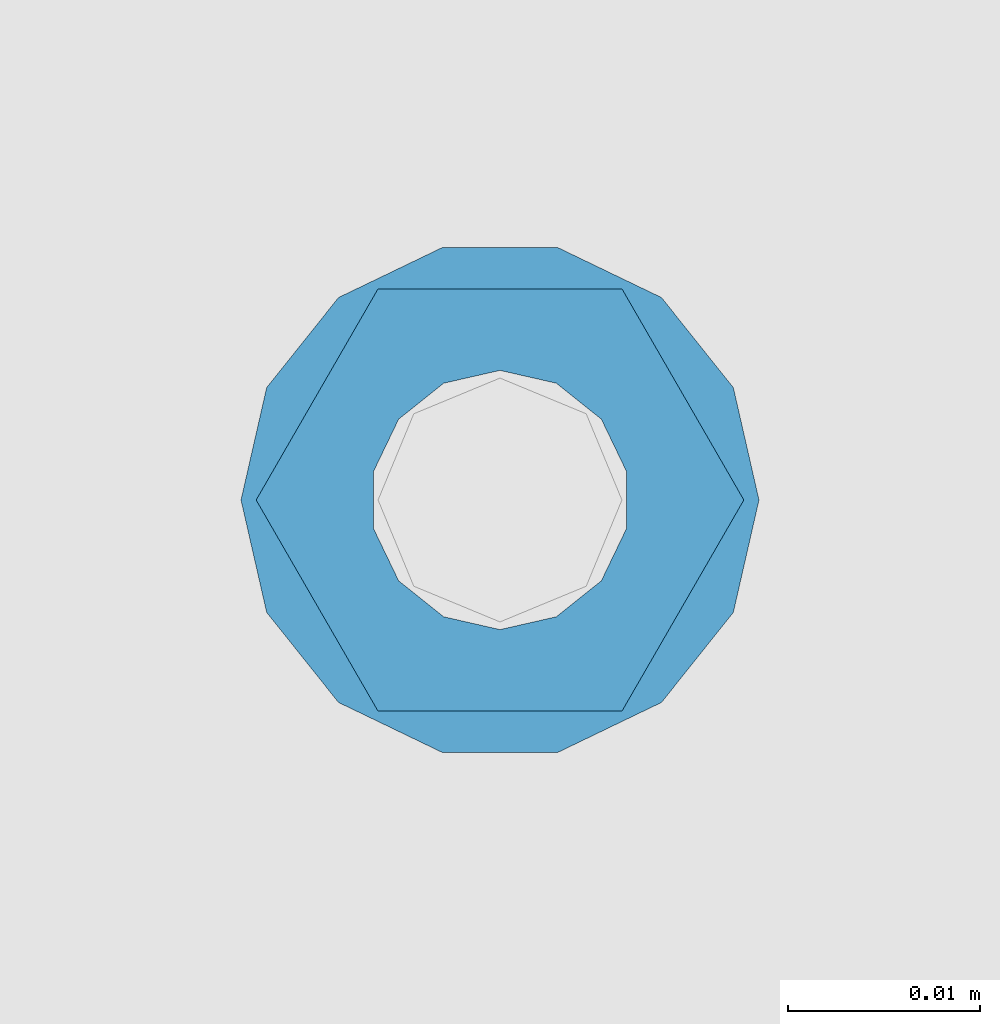
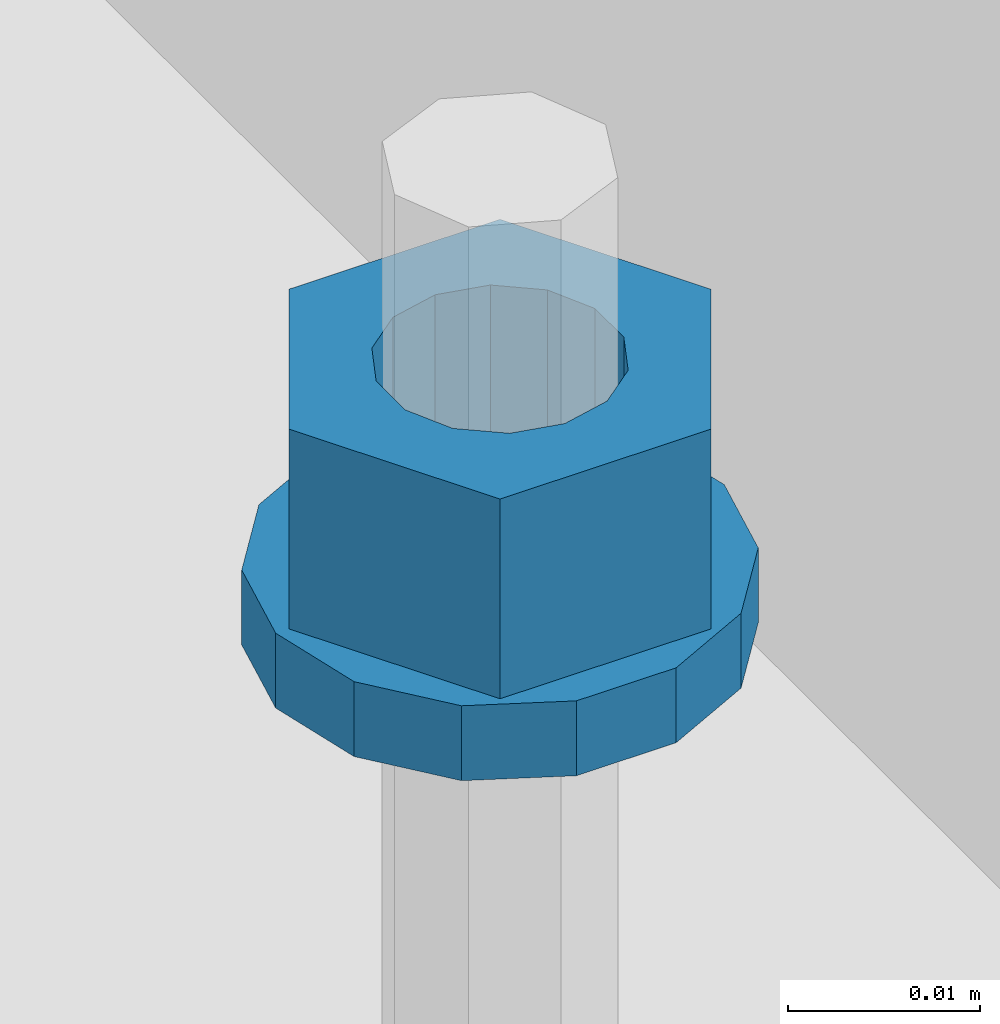
# One storey, part 623 of 1179: 2 columns, 1 element without a shape of its own.
"""IFC2X3 building model written with IfcOpenShell, lengths in millimetres."""

import ifcopenshell
import ifcopenshell.guid

model = None  # the IFC model being written
_history = None  # IfcOwnerHistory: only IFC2X3 demands one
_inside = {}  # id of a spatial element -> (the spatial element, [elements in it])
_under = {}  # id of a project, library or spatial element -> (it, [spatial elements below it])
_declared = {}  # id of a project -> (the project, [libraries it declares])
_typed = {}  # id of a type object -> (the type object, [elements of that type])
_made_of = {}  # id of a material, layer set ... -> (it, [elements and type objects made of it])


def new_model(schema):
    """Start an empty IFC model of exactly this schema.

    Asked for "IFC4X3", IfcOpenShell would pick the latest addendum, in which some entities
    have other attributes; the version numbers below select the first issue.
    IFC2X3 requires an IfcOwnerHistory on every rooted entity: one is made here for all.
    """
    global model, _history
    if schema == "IFC4X3":
        model = ifcopenshell.file(schema_version=(4, 3, 0, 0))
    else:
        model = ifcopenshell.file(schema=schema)
    _inside.clear()
    _under.clear()
    _declared.clear()
    _typed.clear()
    _made_of.clear()
    _history = None
    if model.schema == "IFC2X3":
        org = make("IfcOrganization", Name="unknown")
        user = make(
            "IfcPersonAndOrganization",
            ThePerson=make("IfcPerson", FamilyName="unknown"),
            TheOrganization=org,
        )
        app = make(
            "IfcApplication",
            ApplicationDeveloper=org,
            Version="unknown",
            ApplicationFullName="unknown",
            ApplicationIdentifier="unknown",
        )
        _history = make(
            "IfcOwnerHistory",
            OwningUser=user,
            OwningApplication=app,
            ChangeAction="ADDED",
            CreationDate=0,
        )
    return model


def make(cls, **values):
    """One entity of the class cls with the attributes given. An attribute that is None is left unset."""
    return model.create_entity(
        cls, **{name: value for name, value in values.items() if value is not None}
    )


def rooted(cls, **values):
    """An entity with a GlobalId (a new one), such as an element, a storey or a relation."""
    return make(cls, GlobalId=ifcopenshell.guid.new(), OwnerHistory=_history, **values)


def si_unit(unit_type, name, prefix=None):
    """IfcSIUnit, for example si_unit("LENGTHUNIT", "METRE", prefix="MILLI")."""
    return make("IfcSIUnit", UnitType=unit_type, Prefix=prefix, Name=name)


def assignment(units):
    """IfcUnitAssignment: the units of a project."""
    return None if units is None else make("IfcUnitAssignment", Units=units)


def point(xyz):
    """IfcCartesianPoint."""
    return None if xyz is None else make("IfcCartesianPoint", Coordinates=xyz)


def direction(xyz):
    """IfcDirection."""
    return None if xyz is None else make("IfcDirection", DirectionRatios=xyz)


def frame(location, z_axis=None, x_axis=None):
    """IfcAxis2Placement3D, a coordinate frame: its origin and axes. An axis left out is left unset."""
    return make(
        "IfcAxis2Placement3D",
        Location=point(location),
        Axis=direction(z_axis),
        RefDirection=direction(x_axis),
    )


def origin_with_axes():
    """The frame at (0, 0, 0) with the z axis (0, 0, 1) and the x axis (1, 0, 0) written out."""
    return frame((0.0, 0.0, 0.0), z_axis=(0.0, 0.0, 1.0), x_axis=(1.0, 0.0, 0.0))


def place(relative_to, where):
    """IfcLocalPlacement: puts the frame where relative to a parent placement (None: the world)."""
    return make(
        "IfcLocalPlacement", PlacementRelTo=relative_to, RelativePlacement=where
    )


def context(
    kind, dimensions, precision=None, world=None, true_north=None, identifier=None
):
    """IfcGeometricRepresentationContext, for example the 3D "Model" context."""
    return make(
        "IfcGeometricRepresentationContext",
        ContextIdentifier=identifier,
        ContextType=kind,
        CoordinateSpaceDimension=dimensions,
        Precision=precision,
        WorldCoordinateSystem=world,
        TrueNorth=true_north,
    )


def subcontext(parent, identifier, kind, view, scale=None):
    """IfcGeometricRepresentationSubContext, for example "Body" below "Model"."""
    return make(
        "IfcGeometricRepresentationSubContext",
        ContextIdentifier=identifier,
        ContextType=kind,
        ParentContext=parent,
        TargetScale=scale,
        TargetView=view,
    )


def project(units=None, contexts=None):
    """IfcProject with its units and contexts."""
    return rooted(
        "IfcProject",
        Name="project",
        RepresentationContexts=contexts,
        UnitsInContext=assignment(units),
    )


def spatial(cls, under=None, at=None, **own):
    """A site, building, storey or space (cls), placed at a placement, below another one or the project."""
    s = rooted(cls, ObjectPlacement=at, **own)
    if under is not None:
        _under.setdefault(under.id(), (under, []))[1].append(s)
    return s


def faces_of(points, faces, orient=None, outer=None):
    """IfcFace entities. A face is a list of loops; a loop is a list of indices into points, from 0.

    orient and outer hold one flag for each loop. By default every Orientation is true, the
    first loop of a face is its IfcFaceOuterBound and the others are IfcFaceBound.
    """
    made = []
    for i, loops in enumerate(faces):
        bounds = []
        for j, loop in enumerate(loops):
            is_outer = j == 0 if outer is None else outer[i][j]
            bounds.append(
                make(
                    "IfcFaceOuterBound" if is_outer else "IfcFaceBound",
                    Bound=make("IfcPolyLoop", Polygon=[points[k] for k in loop]),
                    Orientation=True if orient is None else orient[i][j],
                )
            )
        made.append(make("IfcFace", Bounds=bounds))
    return made


def faceted_brep(points, faces, orient=None, outer=None, voids=None):
    """IfcFacetedBrep: a solid bounded by flat faces; with voids (closed shells), ...WithVoids."""
    shared = [point(p) for p in points]
    hull = make("IfcClosedShell", CfsFaces=faces_of(shared, faces, orient, outer))
    if voids is None:
        return make("IfcFacetedBrep", Outer=hull)
    return make(
        "IfcFacetedBrepWithVoids",
        Outer=hull,
        Voids=[
            make(cls, CfsFaces=faces_of(shared, fs, o, b)) for cls, fs, o, b in voids
        ],
    )


def shape(context_of_items, identifier, shape_type, items):
    """IfcShapeRepresentation: the items that make up one representation, for example the "Body"."""
    return make(
        "IfcShapeRepresentation",
        ContextOfItems=context_of_items,
        RepresentationIdentifier=identifier,
        RepresentationType=shape_type,
        Items=items,
    )


def material(Name=None, Category=None):
    """IfcMaterial."""
    return make("IfcMaterial", Name=Name, Category=Category)


def made_of(thing, what):
    """Note that an element or type object is made of a material, layer set ...; save() writes the relation."""
    if what is not None:
        _made_of.setdefault(what.id(), (what, []))[1].append(thing)
    return thing


def type_object(cls, material=None, **own):
    """A type object (cls), such as IfcWallType, which elements share."""
    return made_of(rooted(cls, **own), material)


def element(
    cls,
    number,
    at=None,
    inside=None,
    cuts=None,
    type_object=None,
    material=None,
    context=None,
    identifier="Body",
    shape_type=None,
    held_by="IfcProductDefinitionShape",
    body=None,
    shapes=None,
    **own,
):
    """One element of the class cls, such as IfcWall. Its Tag is "e" and its number.

    at: its placement. inside: the storey or other place that contains it. cuts: it is an
    opening in that element (IfcRelVoidsElement). A single representation is given by context,
    identifier, shape_type and body (its items); several are given by shapes. held_by: the class
    of the entity that holds the representations. save() writes the other relations.
    """
    e = rooted(cls, Tag="e%d" % number, ObjectPlacement=at, **own)
    if body is not None:
        shapes = [shape(context, identifier, shape_type, body)]
    if shapes is not None:
        e.Representation = make(held_by, Representations=shapes)
    if inside is not None:
        _inside.setdefault(inside.id(), (inside, []))[1].append(e)
    if cuts is not None:
        rooted(
            "IfcRelVoidsElement", RelatingBuildingElement=cuts, RelatedOpeningElement=e
        )
    if type_object is not None:
        _typed.setdefault(type_object.id(), (type_object, []))[1].append(e)
    return made_of(e, material)


def aggregate(whole, parts):
    """IfcRelAggregates: a whole, such as a stair, and the parts it consists of."""
    return rooted("IfcRelAggregates", RelatingObject=whole, RelatedObjects=parts)


def save(model, path):
    """Write the relations noted so far, then the file.

    IfcRelAggregates (storeys below a building ...), IfcRelContainedInSpatialStructure (elements
    in a storey), IfcRelDefinesByType, IfcRelAssociatesMaterial and IfcRelDeclares: one each for
    every whole, place, type object, material and project.
    """
    for whole, parts in _under.values():
        aggregate(whole, parts)
    for where, things in _inside.values():
        rooted(
            "IfcRelContainedInSpatialStructure",
            RelatedElements=things,
            RelatingStructure=where,
        )
    for kind, things in _typed.values():
        rooted("IfcRelDefinesByType", RelatedObjects=things, RelatingType=kind)
    for what, things in _made_of.values():
        rooted("IfcRelAssociatesMaterial", RelatedObjects=things, RelatingMaterial=what)
    for by, libraries in _declared.values():
        rooted("IfcRelDeclares", RelatingContext=by, RelatedDefinitions=libraries)
    model.write(path)


model = new_model("IFC2X3")

# Units and contexts
model_context = context("Model", 3, precision=1e-05, world=origin_with_axes())
body_context = subcontext(model_context, "Body", "Model", "MODEL_VIEW")
ifc_project = project(units=[si_unit("LENGTHUNIT", "METRE", prefix="MILLI"), si_unit("AREAUNIT", "SQUARE_METRE"), si_unit("VOLUMEUNIT", "CUBIC_METRE"), si_unit("MASSUNIT", "GRAM", prefix="KILO"), si_unit("TIMEUNIT", "SECOND"), si_unit("PLANEANGLEUNIT", "RADIAN"), si_unit("SOLIDANGLEUNIT", "STERADIAN"), si_unit("THERMODYNAMICTEMPERATUREUNIT", "DEGREE_CELSIUS"), si_unit("LUMINOUSINTENSITYUNIT", "LUMEN")], contexts=[model_context])

# Site, building, storey
site_placement = place(None, origin_with_axes())
site = spatial("IfcSite", under=ifc_project, at=site_placement, CompositionType="ELEMENT")
building_placement = place(site_placement, origin_with_axes())
building = spatial("IfcBuilding", under=site, at=building_placement, Name="Undefined", CompositionType="ELEMENT")
storey_placement = place(building_placement, origin_with_axes())
storey = spatial("IfcBuildingStorey", under=building, at=storey_placement, Name="Undefined", CompositionType="ELEMENT", Elevation=0.0)

# Assembly, columns
assembly_placement = place(storey_placement, origin_with_axes())
assembly = element("IfcElementAssembly", 1, at=assembly_placement, inside=storey, Name="BEAM", AssemblyPlace="NOTDEFINED", PredefinedType="RIGID_FRAME")
ifc_material = material(Name="STEEL/A307")
column_type_1 = type_object("IfcColumnType", Name="1/2_WASHER", PredefinedType="NOTDEFINED")
column_1_placement = place(assembly_placement, frame((101.599999999999, 31026.10025, 4235.45), z_axis=(0.0, 1.0, 0.0), x_axis=(0.0, 0.0, 1.0)))
column_1 = element("IfcColumn", 2, at=column_1_placement, type_object=column_type_1, material=ifc_material, Name="WASHER", ObjectType="1/2_WASHER", context=body_context, shape_type="Brep", body=[
    faceted_brep([(0.0, -13.4899997711182, 0.0), (0.0, -12.1540698217868, -5.85309154138758), (4.76249999999891, -12.1540698217868, -5.85309154138758), (4.76249999999891, -13.4899997711182, 0.0), (0.0, -8.41087728436833, -10.5469065195466), (4.76249999999891, -8.41087728436833, -10.5469065195466), (0.0, -3.00180734814057, -13.1517773121896), (4.76249999999891, -3.00180734814057, -13.1517773121896), (0.0, 3.00180734814057, -13.1517773121896), (4.76249999999891, 3.00180734814057, -13.1517773121896), (0.0, 8.41087728436833, -10.5469065195466), (4.76249999999891, 8.41087728436833, -10.5469065195466), (0.0, 12.1540698217868, -5.85309154138758), (4.76249999999891, 12.1540698217868, -5.85309154138758), (0.0, 13.4899997711182, 0.0), (4.76249999999891, 13.4899997711182, 0.0), (0.0, 12.1540698217868, 5.85309154138758), (4.76249999999891, 12.1540698217868, 5.85309154138758), (0.0, 8.41087728436833, 10.5469065195466), (4.76249999999891, 8.41087728436833, 10.5469065195466), (0.0, 3.00180734814057, 13.1517773121896), (4.76249999999891, 3.00180734814057, 13.1517773121896), (0.0, -3.00180734814057, 13.1517773121896), (4.76249999999891, -3.00180734814057, 13.1517773121896), (0.0, -8.41087728436833, 10.5469065195466), (4.76249999999891, -8.41087728436833, 10.5469065195466), (0.0, -12.1540698217868, 5.85309154138758), (4.76249999999891, -12.1540698217868, 5.85309154138758), (0.0, 0.0, 6.75), (0.0, 2.9287152390425, 6.08153985834178), (4.76249999999891, 2.9287152390425, 6.08153985834178), (4.76249999999891, 0.0, 6.75), (0.0, 5.27736250665839, 4.2085561625463), (4.76249999999891, 5.27736250665839, 4.2085561625463), (0.0, 6.58076340722619, 1.50201630420543), (4.76249999999891, 6.58076340722619, 1.50201630420543), (0.0, 6.58076340722619, -1.50201630420543), (4.76249999999891, 6.58076340722619, -1.50201630420543), (0.0, 5.27736250665839, -4.2085561625463), (4.76249999999891, 5.27736250665839, -4.2085561625463), (0.0, 2.9287152390425, -6.08153985834088), (4.76249999999891, 2.9287152390425, -6.08153985834088), (0.0, 0.0, -6.75), (4.76249999999891, 0.0, -6.75), (0.0, -2.9287152390425, -6.08153985834178), (4.76249999999891, -2.9287152390425, -6.08153985834178), (0.0, -5.27736250665839, -4.2085561625463), (4.76249999999891, -5.27736250665839, -4.2085561625463), (0.0, -6.58076340722619, -1.50201630420543), (4.76249999999891, -6.58076340722619, -1.50201630420543), (0.0, -6.58076340722619, 1.50201630420543), (4.76249999999891, -6.58076340722619, 1.50201630420543), (0.0, -5.27736250665839, 4.2085561625463), (4.76249999999891, -5.27736250665839, 4.2085561625463), (0.0, -2.9287152390425, 6.08153985834088), (4.76249999999891, -2.9287152390425, 6.08153985834088)], [[[0, 1, 2, 3]], [[1, 4, 5, 2]], [[4, 6, 7, 5]], [[6, 8, 9, 7]], [[8, 10, 11, 9]], [[10, 12, 13, 11]], [[12, 14, 15, 13]], [[14, 16, 17, 15]], [[16, 18, 19, 17]], [[18, 20, 21, 19]], [[20, 22, 23, 21]], [[22, 24, 25, 23]], [[24, 26, 27, 25]], [[26, 0, 3, 27]], [[28, 29, 30, 31]], [[29, 32, 33, 30]], [[32, 34, 35, 33]], [[34, 36, 37, 35]], [[36, 38, 39, 37]], [[38, 40, 41, 39]], [[40, 42, 43, 41]], [[42, 44, 45, 43]], [[44, 46, 47, 45]], [[46, 48, 49, 47]], [[48, 50, 51, 49]], [[50, 52, 53, 51]], [[52, 54, 55, 53]], [[54, 28, 31, 55]], [[5, 7, 9, 11, 13, 15, 17, 19, 21, 23, 25, 27, 3, 2], [33, 35, 37, 39, 41, 43, 45, 47, 49, 51, 53, 55, 31, 30]], [[26, 24, 22, 20, 18, 16, 14, 12, 10, 8, 6, 4, 1, 0], [54, 52, 50, 48, 46, 44, 42, 40, 38, 36, 34, 32, 29, 28]]]),
])
column_type_2 = type_object("IfcColumnType", Name="1/2_HEAVY_HEX_NUT", PredefinedType="NOTDEFINED")
column_2_placement = place(assembly_placement, frame((101.599999999999, 31026.10025, 4240.2125), z_axis=(0.0, 1.0, 0.0), x_axis=(0.0, 0.0, 1.0)))
column_2 = element("IfcColumn", 3, at=column_2_placement, type_object=column_type_2, material=ifc_material, Name="NUT", ObjectType="1/2_HEAVY_HEX_NUT", context=body_context, shape_type="Brep", body=[
    faceted_brep([(0.0, -12.7, 0.0), (0.0, -6.34999990463257, -11.0), (12.7000000000007, -6.34999990463257, -11.0), (12.7000000000007, -12.6999998092651, 0.0), (0.0, 6.34999990463257, -11.0), (12.7000000000007, 6.34999990463257, -11.0), (0.0, 12.7, 0.0), (12.7000000000007, 12.6999998092651, 0.0), (0.0, 6.34999990463257, 11.0), (12.7000000000007, 6.34999990463257, 11.0), (0.0, -6.34999990463257, 11.0), (12.7000000000007, -6.34999990463257, 11.0), (0.0, 0.0, 6.75), (0.0, 2.9287152390425, 6.08153985834178), (12.7000000000007, 2.9287152390425, 6.08153985834178), (12.7000000000007, 0.0, 6.75), (0.0, 5.27736250665839, 4.2085561625463), (12.7000000000007, 5.27736250665839, 4.2085561625463), (0.0, 6.58076340722619, 1.50201630420543), (12.7000000000007, 6.58076340722619, 1.50201630420543), (0.0, 6.58076340722619, -1.50201630420543), (12.7000000000007, 6.58076340722619, -1.50201630420543), (0.0, 5.27736250665839, -4.2085561625463), (12.7000000000007, 5.27736250665839, -4.2085561625463), (0.0, 2.9287152390425, -6.08153985834088), (12.7000000000007, 2.9287152390425, -6.08153985834088), (0.0, 0.0, -6.75), (12.7000000000007, 0.0, -6.75), (0.0, -2.9287152390425, -6.08153985834178), (12.7000000000007, -2.9287152390425, -6.08153985834178), (0.0, -5.27736250665839, -4.2085561625463), (12.7000000000007, -5.27736250665839, -4.2085561625463), (0.0, -6.58076340722619, -1.50201630420543), (12.7000000000007, -6.58076340722619, -1.50201630420543), (0.0, -6.58076340722619, 1.50201630420543), (12.7000000000007, -6.58076340722619, 1.50201630420543), (0.0, -5.27736250665839, 4.2085561625463), (12.7000000000007, -5.27736250665839, 4.2085561625463), (0.0, -2.9287152390425, 6.08153985834088), (12.7000000000007, -2.9287152390425, 6.08153985834088)], [[[0, 1, 2, 3]], [[1, 4, 5, 2]], [[4, 6, 7, 5]], [[6, 8, 9, 7]], [[8, 10, 11, 9]], [[10, 0, 3, 11]], [[12, 13, 14, 15]], [[13, 16, 17, 14]], [[16, 18, 19, 17]], [[18, 20, 21, 19]], [[20, 22, 23, 21]], [[22, 24, 25, 23]], [[24, 26, 27, 25]], [[26, 28, 29, 27]], [[28, 30, 31, 29]], [[30, 32, 33, 31]], [[32, 34, 35, 33]], [[34, 36, 37, 35]], [[36, 38, 39, 37]], [[38, 12, 15, 39]], [[5, 7, 9, 11, 3, 2], [17, 19, 21, 23, 25, 27, 29, 31, 33, 35, 37, 39, 15, 14]], [[10, 8, 6, 4, 1, 0], [38, 36, 34, 32, 30, 28, 26, 24, 22, 20, 18, 16, 13, 12]]]),
])
aggregate(assembly, [column_1, column_2])

save(model, "model.ifc")
